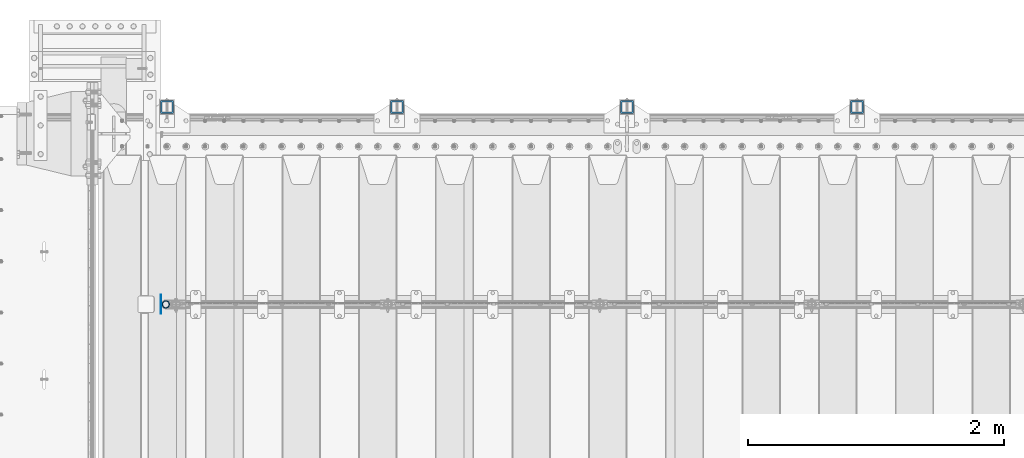
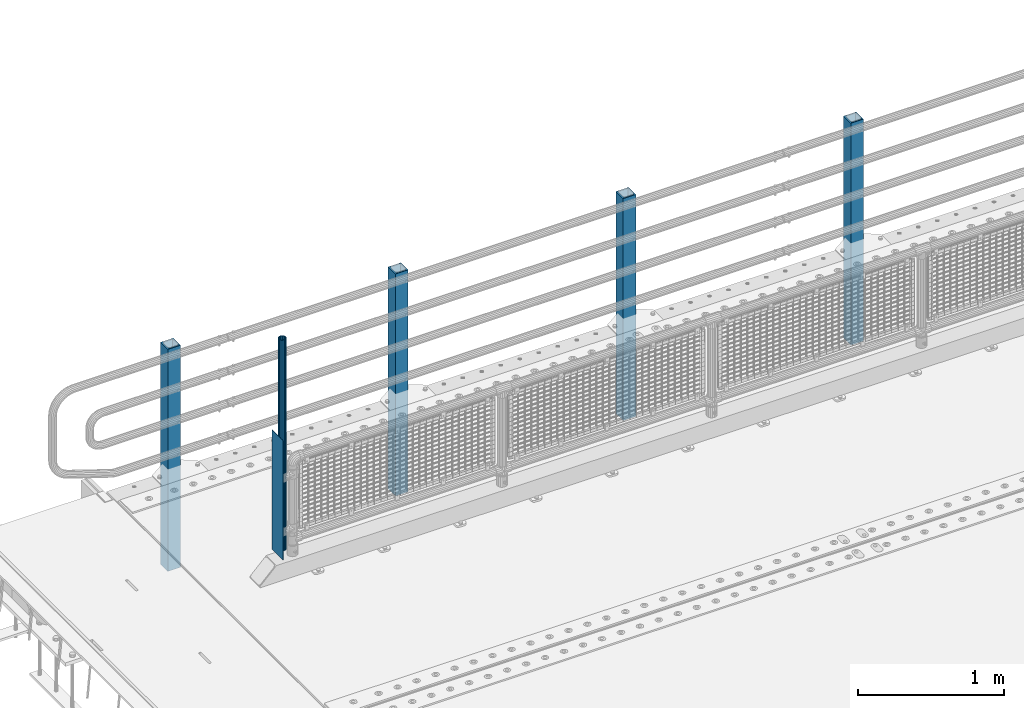
# One storey, part 63 of 240: 6 columns.
"""IFC2X3 building model written with IfcOpenShell, lengths in millimetres."""

from ifc_helpers import new_model, si_unit, frame, origin_with_axes, place, context, subcontext, project, spatial, faceted_brep, material, type_object, element, save


model = new_model("IFC2X3")

# Units and contexts
model_context = context("Model", 3, precision=1e-05, world=origin_with_axes())
body_context = subcontext(model_context, "Body", "Model", "MODEL_VIEW")
ifc_project = project(units=[si_unit("LENGTHUNIT", "METRE", prefix="MILLI"), si_unit("AREAUNIT", "SQUARE_METRE"), si_unit("VOLUMEUNIT", "CUBIC_METRE"), si_unit("MASSUNIT", "GRAM", prefix="KILO"), si_unit("TIMEUNIT", "SECOND"), si_unit("PLANEANGLEUNIT", "RADIAN"), si_unit("SOLIDANGLEUNIT", "STERADIAN"), si_unit("THERMODYNAMICTEMPERATUREUNIT", "DEGREE_CELSIUS"), si_unit("LUMINOUSINTENSITYUNIT", "LUMEN")], contexts=[model_context])

# Site, building, storey
site_placement = place(None, origin_with_axes())
site = spatial("IfcSite", under=ifc_project, at=site_placement, CompositionType="ELEMENT")
building_placement = place(site_placement, origin_with_axes())
building = spatial("IfcBuilding", under=site, at=building_placement, Name="Standard", CompositionType="ELEMENT")
storey_placement = place(building_placement, origin_with_axes())
storey = spatial("IfcBuildingStorey", under=building, at=storey_placement, Name="Undefined", CompositionType="ELEMENT", Elevation=0.0)

# Columns
ifc_material_1 = material(Name="Misc_Undefined")
column_type_1 = type_object("IfcColumnType", PredefinedType="NOTDEFINED")
column_1_placement = place(storey_placement, frame((42991.0, 34664.5, 238.02), z_axis=(1.0, 0.0, 0.0), x_axis=(0.0, 0.0, 1.0)))
element("IfcColumn", 1, at=column_1_placement, inside=storey, type_object=column_type_1, material=ifc_material_1, context=body_context, shape_type="Brep", body=[
    faceted_brep([(0.0, -25.3499999999985, 0.0), (0.0, -23.4203461491634, 9.70102501045767), (1761.98, -23.4203461491634, 9.70102501045767), (1761.98, -25.3499999999985, 0.0), (0.0, -17.9251569030821, 17.9251569030821), (1761.98, -17.9251569030821, 17.9251569030821), (0.0, -9.70102501045767, 23.4203461491634), (1761.98, -9.70102501045767, 23.4203461491634), (0.0, 0.0, 25.3499999999985), (1761.98, 0.0, 25.3499999999985), (0.0, 9.70102501045767, 23.4203461491634), (1761.98, 9.70102501045767, 23.4203461491634), (0.0, 17.9251569030821, 17.9251569030821), (1761.98, 17.9251569030821, 17.9251569030821), (0.0, 23.4203461491634, 9.70102501045767), (1761.98, 23.4203461491634, 9.70102501045767), (0.0, 25.3499999999985, 0.0), (1761.98, 25.3499999999985, 0.0), (0.0, 23.4203461491634, -9.70102501045767), (1761.98, 23.4203461491634, -9.70102501045767), (0.0, 17.9251569030821, -17.9251569030821), (1761.98, 17.9251569030821, -17.9251569030821), (0.0, 9.70102501045767, -23.4203461491634), (1761.98, 9.70102501045767, -23.4203461491634), (0.0, 0.0, -25.3499999999985), (1761.98, 0.0, -25.3499999999985), (0.0, -9.70102501045767, -23.4203461491634), (1761.98, -9.70102501045767, -23.4203461491634), (0.0, -17.9251569030821, -17.9251569030821), (1761.98, -17.9251569030821, -17.9251569030821), (0.0, -23.4203461491634, -9.70102501045767), (1761.98, -23.4203461491634, -9.70102501045767), (0.0, -30.1500000000015, 0.0), (0.0, -27.8549679052157, -11.5379054858058), (1761.98, -27.8549679052157, -11.5379054858058), (1761.98, -30.1500000000015, 0.0), (0.0, -21.3192694527752, -21.3192694527752), (1761.98, -21.3192694527752, -21.3192694527752), (0.0, -11.5379054858058, -27.8549679052157), (1761.98, -11.5379054858058, -27.8549679052157), (0.0, 0.0, -30.1500000000015), (1761.98, 0.0, -30.1500000000015), (0.0, 11.5379054858058, -27.8549679052157), (1761.98, 11.5379054858058, -27.8549679052157), (0.0, 21.3192694527752, -21.3192694527752), (1761.98, 21.3192694527752, -21.3192694527752), (0.0, 27.8549679052157, -11.5379054858058), (1761.98, 27.8549679052157, -11.5379054858058), (0.0, 30.1500000000015, 0.0), (1761.98, 30.1500000000015, 0.0), (0.0, 27.8549679052157, 11.5379054858058), (1761.98, 27.8549679052157, 11.5379054858058), (0.0, 21.3192694527752, 21.3192694527752), (1761.98, 21.3192694527752, 21.3192694527752), (0.0, 11.5379054858058, 27.8549679052157), (1761.98, 11.5379054858058, 27.8549679052157), (0.0, 0.0, 30.1500000000015), (1761.98, 0.0, 30.1500000000015), (0.0, -11.5379054858058, 27.8549679052157), (1761.98, -11.5379054858058, 27.8549679052157), (0.0, -21.3192694527752, 21.3192694527752), (1761.98, -21.3192694527752, 21.3192694527752), (0.0, -27.8549679052157, 11.5379054858058), (1761.98, -27.8549679052157, 11.5379054858058)], [[[0, 1, 2, 3]], [[1, 4, 5, 2]], [[4, 6, 7, 5]], [[6, 8, 9, 7]], [[8, 10, 11, 9]], [[10, 12, 13, 11]], [[12, 14, 15, 13]], [[14, 16, 17, 15]], [[16, 18, 19, 17]], [[18, 20, 21, 19]], [[20, 22, 23, 21]], [[22, 24, 25, 23]], [[24, 26, 27, 25]], [[26, 28, 29, 27]], [[28, 30, 31, 29]], [[30, 0, 3, 31]], [[32, 33, 34, 35]], [[33, 36, 37, 34]], [[36, 38, 39, 37]], [[38, 40, 41, 39]], [[40, 42, 43, 41]], [[42, 44, 45, 43]], [[44, 46, 47, 45]], [[46, 48, 49, 47]], [[48, 50, 51, 49]], [[50, 52, 53, 51]], [[52, 54, 55, 53]], [[54, 56, 57, 55]], [[56, 58, 59, 57]], [[58, 60, 61, 59]], [[60, 62, 63, 61]], [[62, 32, 35, 63]], [[37, 39, 41, 43, 45, 47, 49, 51, 53, 55, 57, 59, 61, 63, 35, 34], [5, 7, 9, 11, 13, 15, 17, 19, 21, 23, 25, 27, 29, 31, 3, 2]], [[62, 60, 58, 56, 54, 52, 50, 48, 46, 44, 42, 40, 38, 36, 33, 32], [30, 28, 26, 24, 22, 20, 18, 16, 14, 12, 10, 8, 6, 4, 1, 0]]]),
])
column_type_2 = type_object("IfcColumnType", PredefinedType="NOTDEFINED")
column_2_placement = place(storey_placement, frame((42954.5, 34664.5, 200.0), z_axis=(0.0, 1.0, 0.0), x_axis=(0.0, 0.0, 1.0)))
element("IfcColumn", 2, at=column_2_placement, inside=storey, type_object=column_type_2, material=ifc_material_1, context=body_context, shape_type="Brep", body=[
    faceted_brep([(0.0, 1.5, -75.0), (0.0, 1.5, 75.0), (1000.0, 1.5, 75.0), (1000.0, 1.5, -75.0), (0.0, -1.5, 75.0), (1000.0, -1.5, 75.0), (0.0, -1.5, -75.0), (1000.0, -1.5, -75.0)], [[[0, 1, 2, 3]], [[1, 4, 5, 2]], [[4, 6, 7, 5]], [[6, 0, 3, 7]], [[5, 7, 3, 2]], [[6, 4, 1, 0]]]),
])
ifc_material_2 = material()
column_type_3 = type_object("IfcColumnType", PredefinedType="NOTDEFINED")
for number, where, z_axis, x_axis in (
    (3, (48400.0000000001, 36210.0000000002, -844.999999999998), (0.0, -1.0, 0.0), (0.0, 0.0, 1.0)),
    (4, (46600.0000000001, 36210.0000000002, -844.999999999998), (0.0, -1.0, 0.0), (0.0, 0.0, 1.0)),
    (5, (44800.0000000001, 36210.0000000002, -844.999999999998), (0.0, -1.0, 0.0), (0.0, 0.0, 1.0)),
    (6, (43000.0000000001, 36210.0000000002, -844.999999999998), (0.0, -1.0, 0.0), (0.0, 0.0, 1.0)),
):
    element("IfcColumn", number, at=place(storey_placement, frame(where, z_axis=z_axis, x_axis=x_axis)), inside=storey, type_object=column_type_3, material=ifc_material_2, context=body_context, shape_type="Brep", body=[
        faceted_brep([(0.0, 40.0, -40.0), (0.0, -40.0, -40.0), (1855.0, -40.0, -40.0), (1855.0, 40.0, -40.0), (0.0, -40.0, 40.0), (1855.0, -40.0, 40.0), (0.0, 40.0, 40.0), (1855.0, 40.0, 40.0), (0.0, 50.0, -50.0), (0.0, 50.0, 50.0), (1855.0, 50.0, 50.0), (1855.0, 50.0, -50.0), (0.0, -50.0, 50.0), (1855.0, -50.0, 50.0), (0.0, -50.0, -50.0), (1855.0, -50.0, -50.0)], [[[0, 1, 2, 3]], [[1, 4, 5, 2]], [[4, 6, 7, 5]], [[6, 0, 3, 7]], [[8, 9, 10, 11]], [[9, 12, 13, 10]], [[12, 14, 15, 13]], [[14, 8, 11, 15]], [[13, 15, 11, 10], [5, 7, 3, 2]], [[14, 12, 9, 8], [6, 4, 1, 0]]]),
    ])

save(model, "model.ifc")
